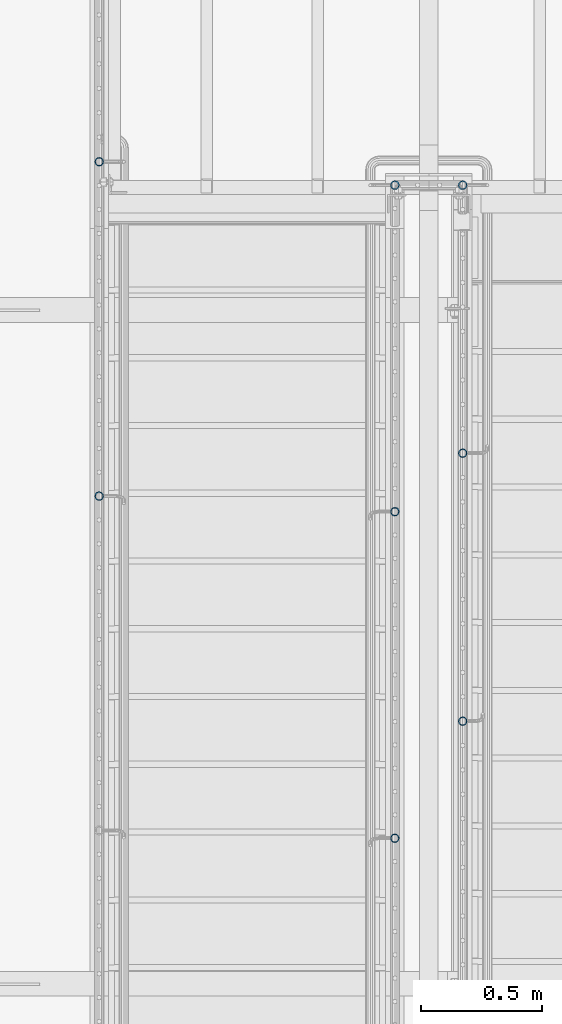
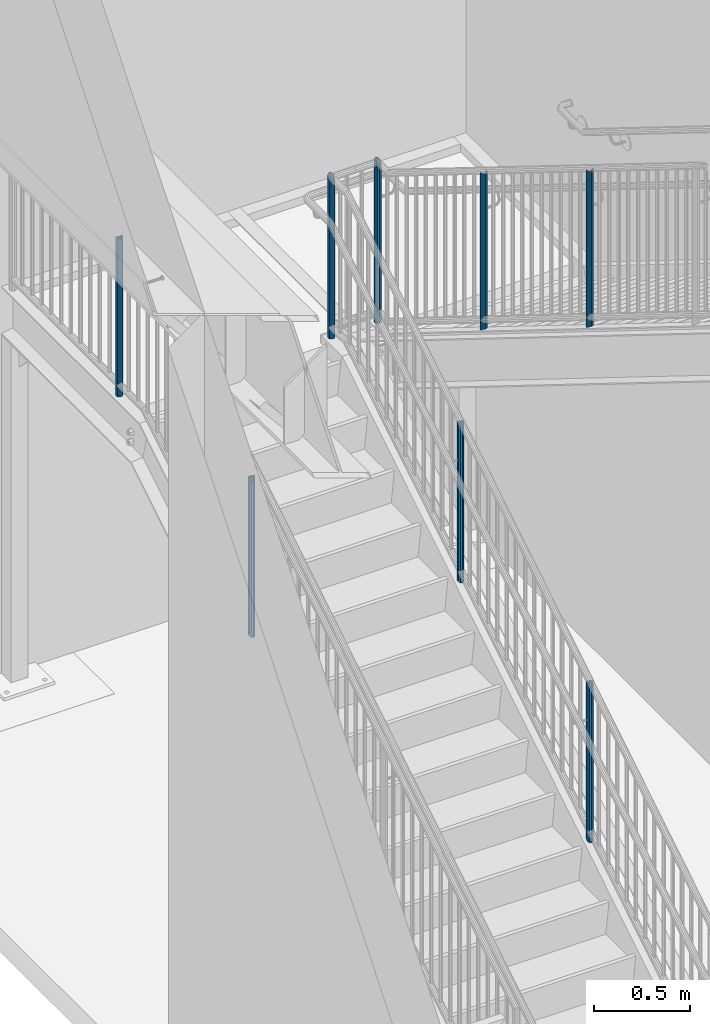
# One storey, part 905 of 1763: 8 columns, 3 elements without a shape of their own.
"""IFC2X3 building model written with IfcOpenShell, lengths in millimetres."""

from ifc_helpers import new_model, si_unit, frame, origin_with_axes, place, context, subcontext, project, spatial, faceted_brep, material, type_object, element, aggregate, save


model = new_model("IFC2X3")

# Units and contexts
model_context = context("Model", 3, precision=1e-05, world=origin_with_axes())
body_context = subcontext(model_context, "Body", "Model", "MODEL_VIEW")
ifc_project = project(units=[si_unit("LENGTHUNIT", "METRE", prefix="MILLI"), si_unit("AREAUNIT", "SQUARE_METRE"), si_unit("VOLUMEUNIT", "CUBIC_METRE"), si_unit("MASSUNIT", "GRAM", prefix="KILO"), si_unit("TIMEUNIT", "SECOND"), si_unit("PLANEANGLEUNIT", "RADIAN"), si_unit("SOLIDANGLEUNIT", "STERADIAN"), si_unit("THERMODYNAMICTEMPERATUREUNIT", "DEGREE_CELSIUS"), si_unit("LUMINOUSINTENSITYUNIT", "LUMEN")], contexts=[model_context])

# Site, building, storey
site_placement = place(None, origin_with_axes())
site = spatial("IfcSite", under=ifc_project, at=site_placement, CompositionType="ELEMENT")
building_placement = place(site_placement, origin_with_axes())
building = spatial("IfcBuilding", under=site, at=building_placement, Name="Undefined", CompositionType="ELEMENT")
storey_placement = place(building_placement, origin_with_axes())
storey = spatial("IfcBuildingStorey", under=building, at=storey_placement, Name="Undefined", CompositionType="ELEMENT", Elevation=0.0)

# Assembly, columns
assembly_1_placement = place(storey_placement, origin_with_axes())
assembly_1 = element("IfcElementAssembly", 1, at=assembly_1_placement, inside=storey, Name="RAIL", AssemblyPlace="NOTDEFINED", PredefinedType="RIGID_FRAME")
ifc_material = material(Name="STEEL/A513")
column_type = type_object("IfcColumnType", PredefinedType="NOTDEFINED")
column_1_placement = place(assembly_1_placement, frame((-86778.5372736932, 36189.9200003693, 2782.8875000151), z_axis=(0.0, -1.0, 0.0), x_axis=(0.0, 0.0, 1.0)))
column_1 = element("IfcColumn", 2, at=column_1_placement, type_object=column_type, material=ifc_material, Name="POST", context=body_context, shape_type="Brep", body=[
    faceted_brep([(999.50221603146, -9.52499999999418, 16.4977839420972), (999.502216040551, -9.52500000032887, 9.99208795623417), (998.864162025985, -7.14375000000291, 12.3733379565674), (996.949999982645, 0.0, 14.2874999999985), (996.949999973554, 0.0, 19.0500000000029), (998.864162026164, 7.14375000000291, 12.3733379565674), (999.502216040551, 9.52499999965949, 9.99208795690356), (999.50221603146, 9.52499999999418, 16.4977839420972), (1015.99999997355, 19.0500000000029, 0.0), (1006.47499997355, 16.4977839420899, 9.52500000000146), (1006.47499998264, 16.4977839420899, -9.52500000000146), (1002.35055399746, 12.3733379565674, 7.14375000000291), (1004.26471604089, 14.2875000000058, 0.0), (1002.35055399746, 12.3733379565674, -7.14375000000291), (999.502216040551, 9.52499999965949, -9.99208795690356), (999.502216040551, 9.52499999999418, -16.4977839420972), (998.864162026164, 7.14375000000291, -12.3733379565674), (996.949999982645, 0.0, -14.2874999999985), (996.949999982645, 0.0, -19.0500000000029), (999.502216040551, -9.52500000032887, -9.99208795623417), (999.502216040551, -9.52499999999418, -16.4977839420972), (998.864162025985, -7.14375000000291, -12.3733379565674), (1015.99999997355, -19.0500000000029, 0.0), (1006.47499998264, -16.4977839420899, -9.52500000000146), (1006.47499997355, -16.4977839420899, 9.52500000000146), (1002.35055399679, -12.3733379565674, -7.14375000000291), (1004.26471604022, -14.2875000000058, 0.0), (1002.35055399679, -12.3733379565674, 7.14375000000291), (0.0, -16.4977839420899, -9.52500000000146), (0.0, -9.52499999999418, -16.4977839420935), (1.45519152283669e-11, 1.81898940354586e-12, -19.0499999999993), (0.0, 9.52499999999418, -16.4977839420935), (0.0, 16.4977839420899, -9.52500000000146), (0.0, 19.0500000000029, 0.0), (0.0, 16.4977839420899, 9.52500000000146), (0.0, 9.52499999999418, 16.4977839420935), (1.45519152283669e-11, 1.81898940354586e-12, 19.0499999999993), (0.0, -9.52499999999418, 16.4977839420935), (0.0, -16.4977839420899, 9.52500000000146), (0.0, -19.0500000000029, 0.0), (0.0, -12.3733379565674, -7.14374999999927), (0.0, -7.14375000000291, -12.373337956571), (0.0, 0.0, -14.2874999999985), (0.0, 7.14375000000291, -12.373337956571), (0.0, 12.3733379565674, -7.14374999999927), (0.0, 14.2875000000058, 0.0), (0.0, 12.3733379565674, 7.14374999999927), (0.0, 7.14375000000291, 12.373337956571), (0.0, 0.0, 14.2874999999985), (0.0, -7.14375000000291, 12.373337956571), (0.0, -12.3733379565674, 7.14374999999927), (0.0, -14.2875000000058, 0.0)], [[[0, 1, 2, 3, 4]], [[4, 3, 5, 6, 7]], [[8, 9, 10]], [[7, 6, 11, 12, 13, 14, 15, 10, 9]], [[16, 17, 18, 15, 14]], [[19, 20, 18, 17, 21]], [[22, 23, 24]], [[24, 23, 20, 19, 25, 26, 27, 1, 0]], [[28, 29, 20, 23]], [[29, 30, 18, 20]], [[30, 31, 15, 18]], [[31, 32, 10, 15]], [[32, 33, 8, 10]], [[33, 34, 9, 8]], [[34, 35, 7, 9]], [[35, 36, 4, 7]], [[36, 37, 0, 4]], [[37, 38, 24, 0]], [[38, 39, 22, 24]], [[39, 28, 23, 22]], [[38, 37, 36, 35, 34, 33, 32, 31, 30, 29, 28, 39], [40, 41, 42, 43, 44, 45, 46, 47, 48, 49, 50, 51]], [[40, 51, 26, 25]], [[21, 41, 40, 25, 19]], [[42, 41, 21, 17]], [[43, 42, 17, 16]], [[44, 43, 16, 14, 13]], [[45, 44, 13, 12]], [[46, 45, 12, 11]], [[5, 47, 46, 11, 6]], [[48, 47, 5, 3]], [[49, 48, 3, 2]], [[50, 49, 2, 1, 27]], [[51, 50, 27, 26]]]),
])
column_2_placement = place(assembly_1_placement, frame((-86778.5372736932, 34811.546667036, 2098.88814734795), z_axis=(0.0, -1.0, 0.0), x_axis=(0.0, 0.0, 1.0)))
column_2 = element("IfcColumn", 3, at=column_2_placement, type_object=column_type, material=ifc_material, Name="POST", context=body_context, shape_type="Brep", body=[
    faceted_brep([(1007.0141087558, 19.0500000000029, 0.0), (989.893652155904, 16.4977839420899, 9.52500000000146), (1001.71485611078, 16.4977839420899, -9.52500000000146), (979.169055938284, -7.14375000000291, 12.3733379565674), (975.72849654122, 0.0, 14.2874999999985), (972.773195552501, 0.0, 19.0500000000029), (977.360608073435, -9.52499999999418, 16.4977839420972), (981.397624287953, -9.52499998081475, 9.99208797574829), (981.397624311756, 9.5250000191736, 9.99208793738944), (977.360608073435, 9.52499999999418, 16.4977839420972), (979.169055926198, 7.14375000000291, 12.3733379565674), (986.517293188597, 12.3733379565674, 7.14375000000291), (993.202998292388, 14.2875000000058, 0.0), (995.383196154722, 12.3733379565674, -7.14375000000291), (993.798517691594, 9.5250000191736, -9.99208793738944), (997.835533929915, 9.52499999999418, -16.4977839420972), (994.525250318502, 7.14375000000291, -12.3733379565674), (993.460302473535, 0.0, -14.2874999999985), (996.415603462254, 0.0, -19.0500000000029), (994.525250330587, -7.14375000000291, -12.3733379565674), (993.798517715397, -9.52499998081475, -9.99208797574829), (997.835533929915, -9.52499999999418, -16.4977839420972), (1007.01410875833, -19.0499999808235, 1.57160684466362e-09), (1001.71485611078, -16.4977839420899, -9.52500000000146), (989.893652155904, -16.4977839420899, 9.52500000000146), (995.383196199836, -12.3733379565674, -7.14375000000291), (993.202998337502, -14.2875000000058, 0.0), (986.517293233711, -12.3733379565674, 7.14375000000291), (5.91060197787965, -16.4977839420899, -9.52500000000146), (10.2374629286942, -9.52499999999418, -16.4977839420972), (11.821203955335, 0.0, -19.0500000000029), (10.2374629286942, 9.52499999999418, -16.4977839420972), (5.91060197787965, 16.4977839420899, -9.52500000000146), (0.0, 19.0500000000029, 0.0), (-5.91060197703064, 16.4977839420899, 9.52500000000146), (-10.2374629278447, 9.52499999999418, 16.4977839420972), (-11.8212039544856, 0.0, 19.0500000000029), (-10.2374629278447, -9.52499999999418, 16.4977839420972), (-5.91060197703064, -16.4977839420899, 9.52500000000146), (0.0, -19.0500000000029, 0.0), (4.43295148351626, -12.3733379565674, -7.14375000000291), (7.67809719662682, -7.14375000000291, -12.3733379565674), (8.86590296660734, 0.0, -14.2874999999985), (7.67809719662682, 7.14375000000291, -12.3733379565674), (4.43295148351626, 12.3733379565674, -7.14375000000291), (0.0, 14.2875000000058, 0.0), (-4.43295148266679, 12.3733379565674, 7.14375000000291), (-7.67809719577735, 7.14375000000291, 12.3733379565674), (-8.86590296575787, 0.0, 14.2874999999985), (-7.67809719577735, -7.14375000000291, 12.3733379565674), (-4.43295148266679, -12.3733379565674, 7.14375000000291), (0.0, -14.2875000000058, 0.0)], [[[0, 1, 2]], [[3, 4, 5, 6, 7]], [[8, 9, 5, 4, 10]], [[2, 1, 9, 8, 11, 12, 13, 14, 15]], [[15, 14, 16, 17, 18]], [[18, 17, 19, 20, 21]], [[22, 23, 24]], [[21, 20, 25, 26, 27, 7, 6, 24, 23]], [[28, 29, 21, 23]], [[29, 30, 18, 21]], [[30, 31, 15, 18]], [[31, 32, 2, 15]], [[32, 33, 0, 2]], [[33, 34, 1, 0]], [[34, 35, 9, 1]], [[35, 36, 5, 9]], [[36, 37, 6, 5]], [[37, 38, 24, 6]], [[38, 39, 22, 24]], [[39, 28, 23, 22]], [[38, 37, 36, 35, 34, 33, 32, 31, 30, 29, 28, 39], [40, 41, 42, 43, 44, 45, 46, 47, 48, 49, 50, 51]], [[19, 41, 40, 25, 20]], [[42, 41, 19, 17]], [[43, 42, 17, 16]], [[44, 43, 16, 14, 13]], [[45, 44, 13, 12]], [[46, 45, 12, 11]], [[10, 47, 46, 11, 8]], [[48, 47, 10, 4]], [[49, 48, 4, 3]], [[50, 49, 3, 7, 27]], [[51, 50, 27, 26]], [[40, 51, 26, 25]]]),
])
aggregate(assembly_1, [column_1, column_2])

assembly_2_placement = place(storey_placement, origin_with_axes())
assembly_2 = element("IfcElementAssembly", 4, at=assembly_2_placement, inside=storey, Name="RAIL", AssemblyPlace="NOTDEFINED", PredefinedType="RIGID_FRAME")
column_3_placement = place(assembly_2_placement, frame((-85279.8721005486, 33883.5999999948, 4092.83761622271), z_axis=(0.0, 1.0, 0.0), x_axis=(0.0, 0.0, 1.0)))
column_3 = element("IfcColumn", 5, at=column_3_placement, type_object=column_type, material=ifc_material, Name="POST", context=body_context, shape_type="Brep", body=[
    faceted_brep([(1007.00613347632, 19.0500000000029, 0.0), (989.881346013277, 16.4977839420899, 9.52500000000146), (1001.70822100366, 16.4977839420899, -9.52500000000146), (979.154707040179, -7.14375000000291, 12.3733379565674), (975.713277301955, 0.0, 14.2874999999985), (972.756558554359, 0.0, 19.0500000000029), (977.34513152453, -9.52499999999418, 16.4977839420972), (981.384084425789, -9.52499996809638, 9.99208798846666), (981.384084465396, 9.52500003189198, 9.99208792467107), (977.34513152453, 9.52499999999418, 16.4977839420972), (979.154707020069, 7.14375000000291, 12.3733379565674), (986.505048410399, 12.3733379565674, 7.14375000000291), (993.193180658401, 14.2875000000058, 0.0), (995.375204653132, 12.3733379565674, -7.14375000000291), (993.790926961777, 9.52500003189198, -9.99208792467107), (997.829879902642, 9.52499999999418, -16.4977839420935), (994.518268303556, 7.14375000000291, -12.373337956571), (993.453589787531, 0.0, -14.2874999999985), (996.410308535128, 0.0, -19.0499999999993), (994.518268323667, -7.14375000000291, -12.373337956571), (993.790927001383, -9.52499996809638, -9.99208798846666), (997.829879902642, -9.52499999999418, -16.4977839420935), (1007.00613347334, -19.0499999681051, -1.84809323400259e-09), (1001.70822100366, -16.4977839420899, -9.52500000000146), (989.881346013277, -16.4977839420899, 9.52500000000146), (995.375204728196, -12.3733379565674, -7.14375000000291), (993.193180733465, -14.2875000000058, 0.0), (986.505048485463, -12.3733379565674, 7.14375000000291), (5.91343749348107, -16.4977839420899, -9.52500000000146), (10.2423741873408, -9.52499999999418, -16.4977839420935), (11.8268749886693, 0.0, -19.0499999999993), (10.2423741873408, 9.52499999999418, -16.4977839420935), (5.91343749348107, 16.4977839420899, -9.52500000000146), (0.0, 19.0500000000029, 0.0), (-5.91343749689622, 16.4977839420899, 9.52500000000146), (-10.2423741907569, 9.52499999999418, 16.4977839420972), (-11.8268749920853, 0.0, 19.0500000000029), (-10.2423741907569, -9.52499999999418, 16.4977839420972), (-5.91343749689622, -16.4977839420899, 9.52500000000146), (0.0, -19.0500000000029, 0.0), (4.43507811968357, -12.3733379565674, -7.14375000000291), (7.68178064007861, -7.14375000000291, -12.373337956571), (8.87015624107516, 0.0, -14.2874999999985), (7.68178064007861, 7.14375000000291, -12.373337956571), (4.43507811968357, 12.3733379565674, -7.14375000000291), (0.0, 14.2875000000058, 0.0), (-4.43507812309963, 12.3733379565674, 7.14375000000291), (-7.68178064349468, 7.14375000000291, 12.3733379565674), (-8.87015624449032, 0.0, 14.2874999999985), (-7.68178064349468, -7.14375000000291, 12.3733379565674), (-4.43507812309963, -12.3733379565674, 7.14375000000291), (0.0, -14.2875000000058, 0.0)], [[[0, 1, 2]], [[3, 4, 5, 6, 7]], [[8, 9, 5, 4, 10]], [[2, 1, 9, 8, 11, 12, 13, 14, 15]], [[15, 14, 16, 17, 18]], [[18, 17, 19, 20, 21]], [[22, 23, 24]], [[21, 20, 25, 26, 27, 7, 6, 24, 23]], [[28, 29, 21, 23]], [[29, 30, 18, 21]], [[30, 31, 15, 18]], [[31, 32, 2, 15]], [[32, 33, 0, 2]], [[33, 34, 1, 0]], [[34, 35, 9, 1]], [[35, 36, 5, 9]], [[36, 37, 6, 5]], [[37, 38, 24, 6]], [[38, 39, 22, 24]], [[39, 28, 23, 22]], [[38, 37, 36, 35, 34, 33, 32, 31, 30, 29, 28, 39], [40, 41, 42, 43, 44, 45, 46, 47, 48, 49, 50, 51]], [[19, 41, 40, 25, 20]], [[42, 41, 19, 17]], [[43, 42, 17, 16]], [[44, 43, 16, 14, 13]], [[45, 44, 13, 12]], [[46, 45, 12, 11]], [[10, 47, 46, 11, 8]], [[48, 47, 10, 4]], [[49, 48, 4, 3]], [[50, 49, 3, 7, 27]], [[51, 50, 27, 26]], [[40, 51, 26, 25]]]),
])
column_4_placement = place(assembly_2_placement, frame((-85279.8721005486, 34988.5000001836, 3406.87886666368), z_axis=(0.0, 1.0, 0.0), x_axis=(0.0, 0.0, 1.0)))
column_4 = element("IfcColumn", 6, at=column_4_placement, type_object=column_type, material=ifc_material, Name="POST", context=body_context, shape_type="Brep", body=[
    faceted_brep([(1007.00613347632, 19.0500000000029, 0.0), (989.881346013277, 16.4977839420899, 9.52500000000146), (1001.70822100366, 16.4977839420899, -9.52500000000146), (979.154707040179, -7.14375000000291, 12.3733379565674), (975.713277301955, 0.0, 14.2874999999985), (972.756558554359, 0.0, 19.0500000000029), (977.34513152453, -9.52499999999418, 16.4977839420972), (981.384084425789, -9.52499996809638, 9.99208798846666), (981.384084465396, 9.52500003189198, 9.99208792467107), (977.34513152453, 9.52499999999418, 16.4977839420972), (979.154707020069, 7.14375000000291, 12.3733379565674), (986.505048410399, 12.3733379565674, 7.14375000000291), (993.193180658401, 14.2875000000058, 0.0), (995.375204653132, 12.3733379565674, -7.14375000000291), (993.790926961777, 9.52500003189198, -9.99208792467107), (997.829879902642, 9.52499999999418, -16.4977839420935), (994.518268303556, 7.14375000000291, -12.373337956571), (993.453589787531, 0.0, -14.2874999999985), (996.410308535128, 0.0, -19.0499999999993), (994.518268323667, -7.14375000000291, -12.373337956571), (993.790927001383, -9.52499996809638, -9.99208798846666), (997.829879902642, -9.52499999999418, -16.4977839420935), (1007.00613347334, -19.0499999681051, -1.84809323400259e-09), (1001.70822100366, -16.4977839420899, -9.52500000000146), (989.881346013277, -16.4977839420899, 9.52500000000146), (995.375204728196, -12.3733379565674, -7.14375000000291), (993.193180733465, -14.2875000000058, 0.0), (986.505048485463, -12.3733379565674, 7.14375000000291), (5.91343749348107, -16.4977839420899, -9.52500000000146), (10.2423741873408, -9.52499999999418, -16.4977839420935), (11.8268749886693, 0.0, -19.0499999999993), (10.2423741873408, 9.52499999999418, -16.4977839420935), (5.91343749348107, 16.4977839420899, -9.52500000000146), (0.0, 19.0500000000029, 0.0), (-5.91343749689622, 16.4977839420899, 9.52500000000146), (-10.2423741907569, 9.52499999999418, 16.4977839420972), (-11.8268749920853, 0.0, 19.0500000000029), (-10.2423741907569, -9.52499999999418, 16.4977839420972), (-5.91343749689622, -16.4977839420899, 9.52500000000146), (0.0, -19.0500000000029, 0.0), (4.43507811968357, -12.3733379565674, -7.14375000000291), (7.68178064007861, -7.14375000000291, -12.373337956571), (8.87015624107516, 0.0, -14.2874999999985), (7.68178064007861, 7.14375000000291, -12.373337956571), (4.43507811968357, 12.3733379565674, -7.14375000000291), (0.0, 14.2875000000058, 0.0), (-4.43507812309963, 12.3733379565674, 7.14375000000291), (-7.68178064349468, 7.14375000000291, 12.3733379565674), (-8.87015624449032, 0.0, 14.2874999999985), (-7.68178064349468, -7.14375000000291, 12.3733379565674), (-4.43507812309963, -12.3733379565674, 7.14375000000291), (0.0, -14.2875000000058, 0.0)], [[[0, 1, 2]], [[3, 4, 5, 6, 7]], [[8, 9, 5, 4, 10]], [[2, 1, 9, 8, 11, 12, 13, 14, 15]], [[15, 14, 16, 17, 18]], [[18, 17, 19, 20, 21]], [[22, 23, 24]], [[21, 20, 25, 26, 27, 7, 6, 24, 23]], [[28, 29, 21, 23]], [[29, 30, 18, 21]], [[30, 31, 15, 18]], [[31, 32, 2, 15]], [[32, 33, 0, 2]], [[33, 34, 1, 0]], [[34, 35, 9, 1]], [[35, 36, 5, 9]], [[36, 37, 6, 5]], [[37, 38, 24, 6]], [[38, 39, 22, 24]], [[39, 28, 23, 22]], [[38, 37, 36, 35, 34, 33, 32, 31, 30, 29, 28, 39], [40, 41, 42, 43, 44, 45, 46, 47, 48, 49, 50, 51]], [[19, 41, 40, 25, 20]], [[42, 41, 19, 17]], [[43, 42, 17, 16]], [[44, 43, 16, 14, 13]], [[45, 44, 13, 12]], [[46, 45, 12, 11]], [[10, 47, 46, 11, 8]], [[48, 47, 10, 4]], [[49, 48, 4, 3]], [[50, 49, 3, 7, 27]], [[51, 50, 27, 26]], [[40, 51, 26, 25]]]),
])
column_5_placement = place(assembly_2_placement, frame((-85279.8721005486, 36093.4000003723, 2782.88750001537), z_axis=(0.0, 1.0, 0.0), x_axis=(0.0, 0.0, 1.0)))
column_5 = element("IfcColumn", 7, at=column_5_placement, type_object=column_type, material=ifc_material, Name="POST", context=body_context, shape_type="Brep", body=[
    faceted_brep([(0.0, -14.2875000000058, 0.0), (0.0, -12.3733379565674, 7.14374999999927), (1023.14375001027, -12.3733379565674, 7.14375000000291), (1015.99999997355, -14.2875000000058, 0.0), (0.0, -7.14375000000291, 12.373337956571), (1028.37333796684, -7.14375000000291, 12.3733379565674), (0.0, 0.0, 14.2874999999985), (1030.28750001027, 0.0, 14.2874999999985), (0.0, 7.14375000000291, 12.373337956571), (1028.37333796684, 7.14375000000291, 12.3733379565674), (0.0, 12.3733379565674, 7.14374999999927), (1023.14375001027, 12.3733379565674, 7.14375000000291), (0.0, 14.2875000000058, 0.0), (1015.99999997355, 14.2875000000058, 0.0), (0.0, 12.3733379565674, -7.14374999999927), (1008.85625001027, 12.3733379565674, -7.14375000000291), (0.0, 7.14375000000291, -12.373337956571), (1003.6266620537, 7.14375000000291, -12.3733379565674), (0.0, 0.0, -14.2874999999985), (1001.71250001027, 0.0, -14.2874999999985), (0.0, -7.14375000000291, -12.373337956571), (1003.6266620537, -7.14375000000291, -12.3733379565674), (0.0, -12.3733379565674, -7.14374999999927), (1008.85625001027, -12.3733379565674, -7.14375000000291), (0.0, -19.0500000000029, 0.0), (0.0, -16.4977839420899, -9.52500000000146), (1006.47499998264, -16.4977839420899, -9.52500000000146), (1015.99999997355, -19.0500000000029, 0.0), (0.0, -9.52499999999418, -16.4977839420935), (999.502216040551, -9.52499999999418, -16.4977839420972), (1.45519152283669e-11, 1.81898940354586e-12, -19.0499999999993), (996.949999982645, 0.0, -19.0500000000029), (0.0, 9.52499999999418, -16.4977839420935), (999.502216040551, 9.52499999999418, -16.4977839420972), (0.0, 16.4977839420899, -9.52500000000146), (1006.47499998264, 16.4977839420899, -9.52500000000146), (0.0, 19.0500000000029, 0.0), (1015.99999997355, 19.0500000000029, 0.0), (0.0, 16.4977839420899, 9.52500000000146), (1025.52500001027, 16.4977839420899, 9.52500000000146), (0.0, 9.52499999999418, 16.4977839420935), (1032.49778395236, 9.52499999999418, 16.4977839420972), (1.45519152283669e-11, 1.81898940354586e-12, 19.0499999999993), (1035.05000001027, 0.0, 19.0500000000029), (0.0, -9.52499999999418, 16.4977839420935), (1032.49778395236, -9.52499999999418, 16.4977839420972), (0.0, -16.4977839420899, 9.52500000000146), (1025.52500001027, -16.4977839420899, 9.52500000000146)], [[[0, 1, 2, 3]], [[1, 4, 5, 2]], [[4, 6, 7, 5]], [[6, 8, 9, 7]], [[8, 10, 11, 9]], [[10, 12, 13, 11]], [[12, 14, 15, 13]], [[14, 16, 17, 15]], [[16, 18, 19, 17]], [[18, 20, 21, 19]], [[20, 22, 23, 21]], [[22, 0, 3, 23]], [[24, 25, 26, 27]], [[25, 28, 29, 26]], [[28, 30, 31, 29]], [[30, 32, 33, 31]], [[32, 34, 35, 33]], [[34, 36, 37, 35]], [[36, 38, 39, 37]], [[38, 40, 41, 39]], [[40, 42, 43, 41]], [[42, 44, 45, 43]], [[44, 46, 47, 45]], [[46, 24, 27, 47]], [[29, 31, 33, 35, 37, 39, 41, 43, 45, 47, 27, 26], [5, 7, 9, 11, 13, 15, 17, 19, 21, 23, 3, 2]], [[46, 44, 42, 40, 38, 36, 34, 32, 30, 28, 25, 24], [22, 20, 18, 16, 14, 12, 10, 8, 6, 4, 1, 0]]]),
])
aggregate(assembly_2, [column_3, column_4, column_5])

assembly_3_placement = place(storey_placement, origin_with_axes())
assembly_3 = element("IfcElementAssembly", 8, at=assembly_3_placement, inside=storey, Name="RAIL", AssemblyPlace="NOTDEFINED", PredefinedType="RIGID_FRAME")
column_6_placement = place(assembly_3_placement, frame((-85559.3372736932, 36093.4000003693, 2782.8875000151), z_axis=(0.0, -1.0, 0.0), x_axis=(0.0, 0.0, 1.0)))
column_6 = element("IfcColumn", 9, at=column_6_placement, type_object=column_type, material=ifc_material, Name="POST", context=body_context, shape_type="Brep", body=[
    faceted_brep([(0.0, -14.2875000000058, 0.0), (0.0, -12.3733379565674, 7.14374999999927), (1008.85624997355, -12.3733379565674, 7.14375000000291), (1015.99999997355, -14.2875000000058, 0.0), (0.0, -7.14375000000291, 12.373337956571), (1003.62666201698, -7.14375000000291, 12.3733379565674), (0.0, 0.0, 14.2874999999985), (1001.71249997355, 0.0, 14.2874999999985), (0.0, 7.14375000000291, 12.373337956571), (1003.62666201698, 7.14375000000291, 12.3733379565674), (0.0, 12.3733379565674, 7.14374999999927), (1008.85624997355, 12.3733379565674, 7.14375000000291), (0.0, 14.2875000000058, 0.0), (1015.99999997355, 14.2875000000058, 0.0), (0.0, 12.3733379565674, -7.14374999999927), (1023.14374997355, 12.3733379565674, -7.14375000000291), (0.0, 7.14375000000291, -12.373337956571), (1028.37333793012, 7.14375000000291, -12.3733379565674), (0.0, 0.0, -14.2874999999985), (1030.28749997355, 0.0, -14.2874999999985), (0.0, -7.14375000000291, -12.373337956571), (1028.37333793012, -7.14375000000291, -12.3733379565674), (0.0, -12.3733379565674, -7.14374999999927), (1023.14374997355, -12.3733379565674, -7.14375000000291), (0.0, -19.0500000000029, 0.0), (0.0, -16.4977839420899, -9.52500000000146), (1025.52499997355, -16.4977839420899, -9.52500000000146), (1015.99999997355, -19.0500000000029, 0.0), (0.0, -9.52499999999418, -16.4977839420935), (1032.49778391565, -9.52499999999418, -16.4977839420972), (1.45519152283669e-11, 1.81898940354586e-12, -19.0499999999993), (1035.04999997355, 0.0, -19.0500000000029), (0.0, 9.52499999999418, -16.4977839420935), (1032.49778391565, 9.52499999999418, -16.4977839420972), (0.0, 16.4977839420899, -9.52500000000146), (1025.52499997355, 16.4977839420899, -9.52500000000146), (0.0, 19.0500000000029, 0.0), (1015.99999997355, 19.0500000000029, 0.0), (0.0, 16.4977839420899, 9.52500000000146), (1006.47499997355, 16.4977839420899, 9.52500000000146), (0.0, 9.52499999999418, 16.4977839420935), (999.50221603146, 9.52499999999418, 16.4977839420972), (1.45519152283669e-11, 1.81898940354586e-12, 19.0499999999993), (996.949999973554, 0.0, 19.0500000000029), (0.0, -9.52499999999418, 16.4977839420935), (999.50221603146, -9.52499999999418, 16.4977839420972), (0.0, -16.4977839420899, 9.52500000000146), (1006.47499997355, -16.4977839420899, 9.52500000000146)], [[[0, 1, 2, 3]], [[1, 4, 5, 2]], [[4, 6, 7, 5]], [[6, 8, 9, 7]], [[8, 10, 11, 9]], [[10, 12, 13, 11]], [[12, 14, 15, 13]], [[14, 16, 17, 15]], [[16, 18, 19, 17]], [[18, 20, 21, 19]], [[20, 22, 23, 21]], [[22, 0, 3, 23]], [[24, 25, 26, 27]], [[25, 28, 29, 26]], [[28, 30, 31, 29]], [[30, 32, 33, 31]], [[32, 34, 35, 33]], [[34, 36, 37, 35]], [[36, 38, 39, 37]], [[38, 40, 41, 39]], [[40, 42, 43, 41]], [[42, 44, 45, 43]], [[44, 46, 47, 45]], [[46, 24, 27, 47]], [[29, 31, 33, 35, 37, 39, 41, 43, 45, 47, 27, 26], [5, 7, 9, 11, 13, 15, 17, 19, 21, 23, 3, 2]], [[46, 44, 42, 40, 38, 36, 34, 32, 30, 28, 25, 24], [22, 20, 18, 16, 14, 12, 10, 8, 6, 4, 1, 0]]]),
])
column_7_placement = place(assembly_3_placement, frame((-85559.3372736932, 34747.2000003711, 2058.95874732823), z_axis=(0.0, -1.0, 0.0), x_axis=(0.0, 0.0, 1.0)))
column_7 = element("IfcColumn", 10, at=column_7_placement, type_object=column_type, material=ifc_material, Name="POST", context=body_context, shape_type="Brep", body=[
    faceted_brep([(1007.0141087558, 19.0500000000029, 0.0), (989.893652155904, 16.4977839420899, 9.52500000000146), (1001.71485611078, 16.4977839420899, -9.52500000000146), (979.169055938284, -7.14375000000291, 12.3733379565674), (975.72849654122, 0.0, 14.2874999999985), (972.773195552501, 0.0, 19.0500000000029), (977.360608073435, -9.52499999999418, 16.4977839420972), (981.397624287953, -9.52499998081475, 9.99208797574829), (981.397624311756, 9.5250000191736, 9.99208793738944), (977.360608073435, 9.52499999999418, 16.4977839420972), (979.169055926198, 7.14375000000291, 12.3733379565674), (986.517293188597, 12.3733379565674, 7.14375000000291), (993.202998292388, 14.2875000000058, 0.0), (995.383196154722, 12.3733379565674, -7.14375000000291), (993.798517691594, 9.5250000191736, -9.99208793738944), (997.835533929915, 9.52499999999418, -16.4977839420972), (994.525250318502, 7.14375000000291, -12.3733379565674), (993.460302473535, 0.0, -14.2874999999985), (996.415603462254, 0.0, -19.0500000000029), (994.525250330587, -7.14375000000291, -12.3733379565674), (993.798517715397, -9.52499998081475, -9.99208797574829), (997.835533929915, -9.52499999999418, -16.4977839420972), (1007.01410875833, -19.0499999808235, 1.57160684466362e-09), (1001.71485611078, -16.4977839420899, -9.52500000000146), (989.893652155904, -16.4977839420899, 9.52500000000146), (995.383196199836, -12.3733379565674, -7.14375000000291), (993.202998337502, -14.2875000000058, 0.0), (986.517293233711, -12.3733379565674, 7.14375000000291), (5.91060197787965, -16.4977839420899, -9.52500000000146), (10.2374629286942, -9.52499999999418, -16.4977839420972), (11.821203955335, 0.0, -19.0500000000029), (10.2374629286942, 9.52499999999418, -16.4977839420972), (5.91060197787965, 16.4977839420899, -9.52500000000146), (0.0, 19.0500000000029, 0.0), (-5.91060197703064, 16.4977839420899, 9.52500000000146), (-10.2374629278447, 9.52499999999418, 16.4977839420972), (-11.8212039544856, 0.0, 19.0500000000029), (-10.2374629278447, -9.52499999999418, 16.4977839420972), (-5.91060197703064, -16.4977839420899, 9.52500000000146), (0.0, -19.0500000000029, 0.0), (4.43295148351626, -12.3733379565674, -7.14375000000291), (7.67809719662682, -7.14375000000291, -12.3733379565674), (8.86590296660734, 0.0, -14.2874999999985), (7.67809719662682, 7.14375000000291, -12.3733379565674), (4.43295148351626, 12.3733379565674, -7.14375000000291), (0.0, 14.2875000000058, 0.0), (-4.43295148266679, 12.3733379565674, 7.14375000000291), (-7.67809719577735, 7.14375000000291, 12.3733379565674), (-8.86590296575787, 0.0, 14.2874999999985), (-7.67809719577735, -7.14375000000291, 12.3733379565674), (-4.43295148266679, -12.3733379565674, 7.14375000000291), (0.0, -14.2875000000058, 0.0)], [[[0, 1, 2]], [[3, 4, 5, 6, 7]], [[8, 9, 5, 4, 10]], [[2, 1, 9, 8, 11, 12, 13, 14, 15]], [[15, 14, 16, 17, 18]], [[18, 17, 19, 20, 21]], [[22, 23, 24]], [[21, 20, 25, 26, 27, 7, 6, 24, 23]], [[28, 29, 21, 23]], [[29, 30, 18, 21]], [[30, 31, 15, 18]], [[31, 32, 2, 15]], [[32, 33, 0, 2]], [[33, 34, 1, 0]], [[34, 35, 9, 1]], [[35, 36, 5, 9]], [[36, 37, 6, 5]], [[37, 38, 24, 6]], [[38, 39, 22, 24]], [[39, 28, 23, 22]], [[38, 37, 36, 35, 34, 33, 32, 31, 30, 29, 28, 39], [40, 41, 42, 43, 44, 45, 46, 47, 48, 49, 50, 51]], [[19, 41, 40, 25, 20]], [[42, 41, 19, 17]], [[43, 42, 17, 16]], [[44, 43, 16, 14, 13]], [[45, 44, 13, 12]], [[46, 45, 12, 11]], [[10, 47, 46, 11, 8]], [[48, 47, 10, 4]], [[49, 48, 4, 3]], [[50, 49, 3, 7, 27]], [[51, 50, 27, 26]], [[40, 51, 26, 25]]]),
])
column_8_placement = place(assembly_3_placement, frame((-85559.3372736932, 33401.0000003702, 1223.59366783948), z_axis=(0.0, -1.0, 0.0), x_axis=(0.0, 0.0, 1.0)))
column_8 = element("IfcColumn", 11, at=column_8_placement, type_object=column_type, material=ifc_material, Name="POST", context=body_context, shape_type="Brep", body=[
    faceted_brep([(1007.0141087558, 19.0500000000029, 0.0), (989.893652155904, 16.4977839420899, 9.52500000000146), (1001.71485611078, 16.4977839420899, -9.52500000000146), (979.169055938284, -7.14375000000291, 12.3733379565674), (975.72849654122, 0.0, 14.2874999999985), (972.773195552501, 0.0, 19.0500000000029), (977.360608073435, -9.52499999999418, 16.4977839420972), (981.397624287953, -9.52499998081475, 9.99208797574829), (981.397624311756, 9.5250000191736, 9.99208793738944), (977.360608073435, 9.52499999999418, 16.4977839420972), (979.169055926198, 7.14375000000291, 12.3733379565674), (986.517293188597, 12.3733379565674, 7.14375000000291), (993.202998292388, 14.2875000000058, 0.0), (995.383196154722, 12.3733379565674, -7.14375000000291), (993.798517691594, 9.5250000191736, -9.99208793738944), (997.835533929915, 9.52499999999418, -16.4977839420972), (994.525250318502, 7.14375000000291, -12.3733379565674), (993.460302473535, 0.0, -14.2874999999985), (996.415603462254, 0.0, -19.0500000000029), (994.525250330587, -7.14375000000291, -12.3733379565674), (993.798517715397, -9.52499998081475, -9.99208797574829), (997.835533929915, -9.52499999999418, -16.4977839420972), (1007.01410875833, -19.0499999808235, 1.57160684466362e-09), (1001.71485611078, -16.4977839420899, -9.52500000000146), (989.893652155904, -16.4977839420899, 9.52500000000146), (995.383196199836, -12.3733379565674, -7.14375000000291), (993.202998337502, -14.2875000000058, 0.0), (986.517293233711, -12.3733379565674, 7.14375000000291), (5.91060197787965, -16.4977839420899, -9.52500000000146), (10.2374629286942, -9.52499999999418, -16.4977839420972), (11.821203955335, 0.0, -19.0500000000029), (10.2374629286942, 9.52499999999418, -16.4977839420972), (5.91060197787965, 16.4977839420899, -9.52500000000146), (0.0, 19.0500000000029, 0.0), (-5.91060197703064, 16.4977839420899, 9.52500000000146), (-10.2374629278447, 9.52499999999418, 16.4977839420972), (-11.8212039544856, 0.0, 19.0500000000029), (-10.2374629278447, -9.52499999999418, 16.4977839420972), (-5.91060197703064, -16.4977839420899, 9.52500000000146), (0.0, -19.0500000000029, 0.0), (4.43295148351626, -12.3733379565674, -7.14375000000291), (7.67809719662682, -7.14375000000291, -12.3733379565674), (8.86590296660734, 0.0, -14.2874999999985), (7.67809719662682, 7.14375000000291, -12.3733379565674), (4.43295148351626, 12.3733379565674, -7.14375000000291), (0.0, 14.2875000000058, 0.0), (-4.43295148266679, 12.3733379565674, 7.14375000000291), (-7.67809719577735, 7.14375000000291, 12.3733379565674), (-8.86590296575787, 0.0, 14.2874999999985), (-7.67809719577735, -7.14375000000291, 12.3733379565674), (-4.43295148266679, -12.3733379565674, 7.14375000000291), (0.0, -14.2875000000058, 0.0)], [[[0, 1, 2]], [[3, 4, 5, 6, 7]], [[8, 9, 5, 4, 10]], [[2, 1, 9, 8, 11, 12, 13, 14, 15]], [[15, 14, 16, 17, 18]], [[18, 17, 19, 20, 21]], [[22, 23, 24]], [[21, 20, 25, 26, 27, 7, 6, 24, 23]], [[28, 29, 21, 23]], [[29, 30, 18, 21]], [[30, 31, 15, 18]], [[31, 32, 2, 15]], [[32, 33, 0, 2]], [[33, 34, 1, 0]], [[34, 35, 9, 1]], [[35, 36, 5, 9]], [[36, 37, 6, 5]], [[37, 38, 24, 6]], [[38, 39, 22, 24]], [[39, 28, 23, 22]], [[38, 37, 36, 35, 34, 33, 32, 31, 30, 29, 28, 39], [40, 41, 42, 43, 44, 45, 46, 47, 48, 49, 50, 51]], [[19, 41, 40, 25, 20]], [[42, 41, 19, 17]], [[43, 42, 17, 16]], [[44, 43, 16, 14, 13]], [[45, 44, 13, 12]], [[46, 45, 12, 11]], [[10, 47, 46, 11, 8]], [[48, 47, 10, 4]], [[49, 48, 4, 3]], [[50, 49, 3, 7, 27]], [[51, 50, 27, 26]], [[40, 51, 26, 25]]]),
])
aggregate(assembly_3, [column_6, column_7, column_8])

save(model, "model.ifc")
